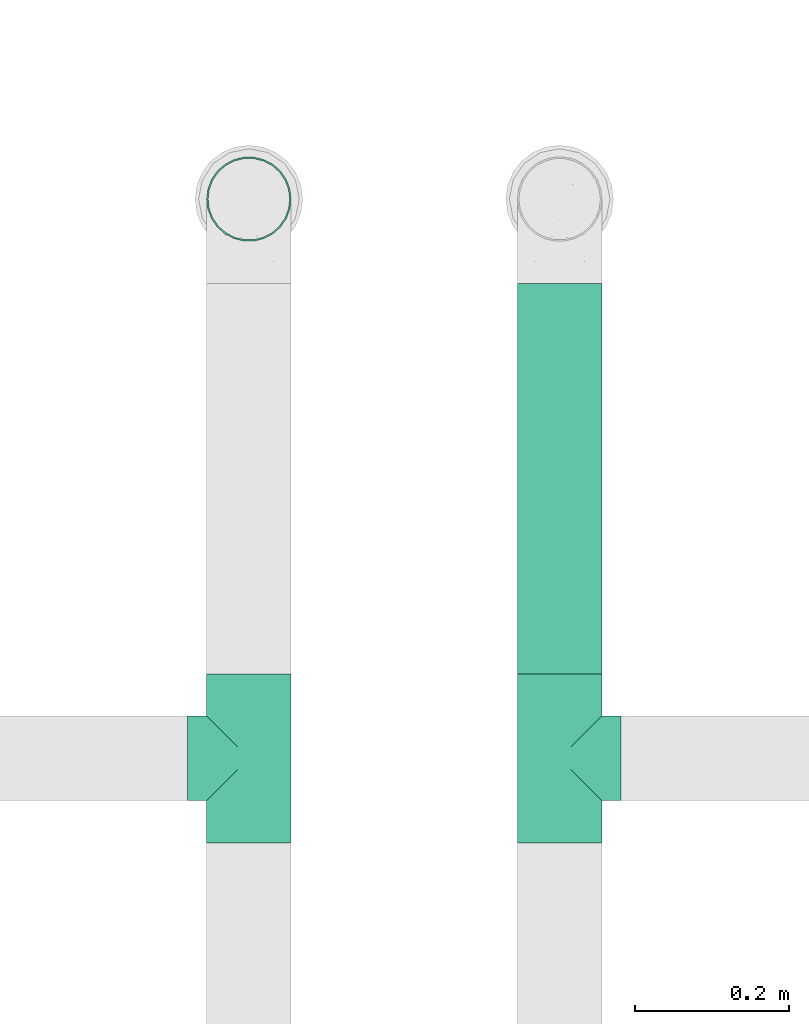
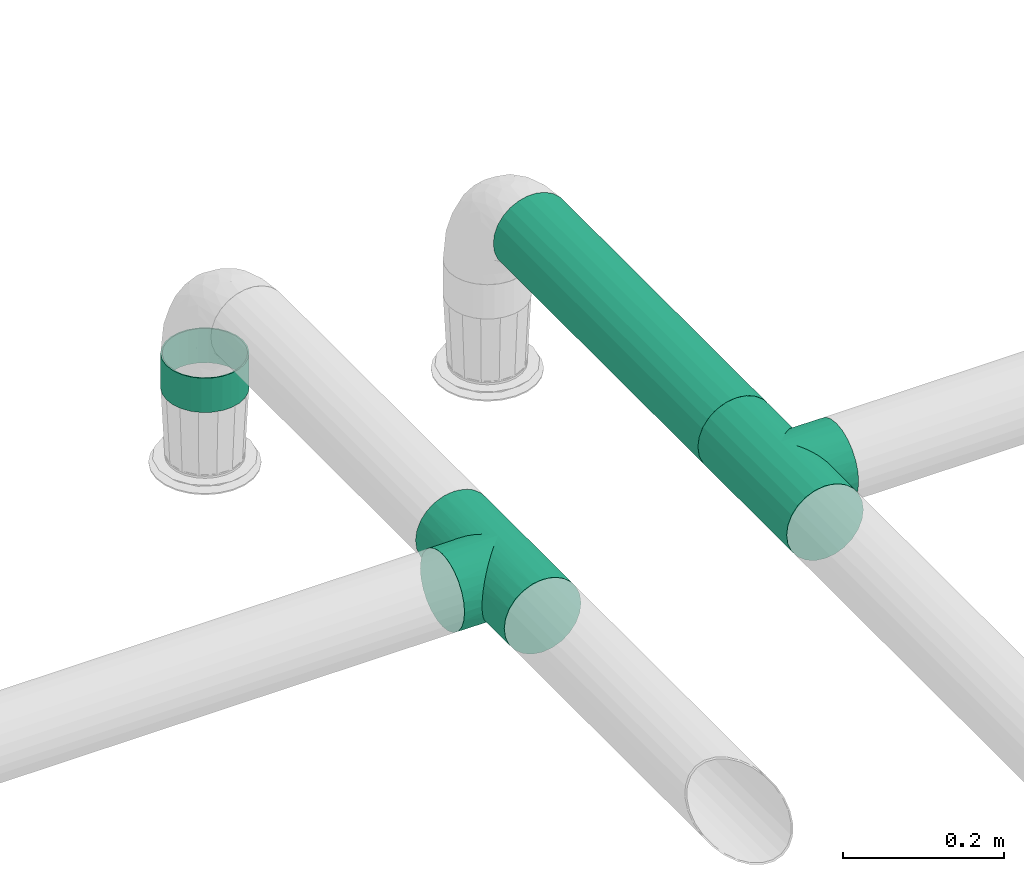
# One storey, part 31 of 115: 2 flow fittings, 2 flow segments.
"""IFC2X3 building model written with IfcOpenShell, lengths in millimetres."""

from ifc_helpers import new_model, entity, si_unit, converted_unit, derived_unit, direction, frame, origin_with_axes, origin_2d_with_axis, place, context, subcontext, project, spatial, hollow_circle, extrude, open_shell, surface_model, source, transform, mapped, material, layer, layer_set, layer_usage, type_object, element, save


model = new_model("IFC2X3")

# Units and contexts
model_context = context("Model", 3, precision=1e-05, world=origin_with_axes(), true_north=direction((0.0, 1.0)))
body_context = subcontext(model_context, "Body", "Model", "MODEL_VIEW")
ifc_project = project(units=[si_unit("AREAUNIT", "SQUARE_METRE"), si_unit("VOLUMEUNIT", "CUBIC_METRE", prefix="DECI"), si_unit("TIMEUNIT", "SECOND"), si_unit("THERMODYNAMICTEMPERATUREUNIT", "DEGREE_CELSIUS"), si_unit("PRESSUREUNIT", "PASCAL"), si_unit("MASSUNIT", "GRAM", prefix="KILO"), si_unit("LENGTHUNIT", "METRE", prefix="MILLI"), si_unit("POWERUNIT", "WATT"), si_unit("ELECTRICCURRENTUNIT", "AMPERE"), si_unit("ELECTRICVOLTAGEUNIT", "VOLT"), derived_unit("VOLUMETRICFLOWRATEUNIT", [(si_unit("VOLUMEUNIT", "CUBIC_METRE", prefix="DECI"), 1), (si_unit("TIMEUNIT", "SECOND"), -1)]), derived_unit("LINEARVELOCITYUNIT", [(si_unit("LENGTHUNIT", "METRE"), 1), (si_unit("TIMEUNIT", "SECOND"), -1)]), derived_unit("MASSDENSITYUNIT", [(si_unit("MASSUNIT", "GRAM", prefix="KILO"), 1), (si_unit("VOLUMEUNIT", "CUBIC_METRE"), -1)]), converted_unit("PLANEANGLEUNIT", "DEGREE", entity("IfcRatioMeasure", 0.01745), si_unit("PLANEANGLEUNIT", "RADIAN"), dimensions=[0, 0, 0, 0, 0, 0, 0])], contexts=[model_context])

# Site, building, storey
site_placement = place(None, origin_with_axes())
site = spatial("IfcSite", under=ifc_project, at=site_placement, CompositionType="ELEMENT")
building_placement = place(site_placement, origin_with_axes())
building = spatial("IfcBuilding", under=site, at=building_placement, Name="mc-building", CompositionType="ELEMENT")
storey_placement = place(building_placement, frame((0.0, 0.0, 2950.0), z_axis=(0.0, 0.0, 1.0), x_axis=(1.0, 0.0, 0.0)))
storey = spatial("IfcBuildingStorey", under=building, at=storey_placement, Name="2. Korrus", CompositionType="ELEMENT", Elevation=2950.0)

# Flow fitting
duct_fitting_type = type_object("IfcDuctFittingType", PredefinedType="JUNCTION")
shared_shape_1 = source(origin_with_axes(), body_context, "Body", "SurfaceModel", [
    surface_model("IfcShellBasedSurfaceModel", [(0.0, -80.0, -55.0), (14.23505, -80.0, -53.12592), (-14.23505, -80.0, -53.12592), (-53.12592, -80.0, 14.23505), (-27.5, -80.0, -47.63139), (-47.63139, -80.0, -27.5), (-38.89087, -80.0, -38.89087), (55.0, -80.0, 0.0), (53.12592, -80.0, 14.23505), (38.89087, -80.0, -38.89087), (27.5, -80.0, -47.63139), (53.12592, -80.0, -14.23505), (47.63139, -80.0, -27.5), (-53.12592, -80.0, -14.23505), (-47.63139, -80.0, 27.5), (-38.89087, -80.0, 38.89087), (14.23505, -80.0, 53.12592), (-27.5, -80.0, 47.63139), (-14.23505, -80.0, 53.12592), (47.63139, -80.0, 27.5), (38.89087, -80.0, 38.89087), (27.5, -80.0, 47.63139), (0.0, -80.0, 55.0), (-55.0, -80.0, 0.0), (0.0, 0.0, 55.0), (-7.4066, -7.4066, 54.49901), (-14.74521, -14.74521, 52.98659), (-21.93978, -21.93978, 50.43457), (-28.89905, -28.89905, 46.79578), (-35.50357, -35.50357, 42.00591), (-41.58668, -41.58668, 35.99373), (-46.92319, -46.92319, 28.69171), (-51.19777, -51.19777, 20.0945), (-50.37866, -80.0, 20.86752), (-54.01174, -54.01174, 10.37938), (-55.0, -55.0, 0.0), (-54.06296, -80.0, 7.11752), (-54.01174, -54.01174, -10.37938), (-51.19777, -51.19777, -20.0945), (-54.06296, -80.0, -7.11752), (-46.92319, -46.92319, -28.69171), (-41.58668, -41.58668, -35.99373), (-50.37866, -80.0, -20.86752), (-35.50357, -35.50357, -42.00591), (-21.93978, -21.93978, -50.43457), (-14.74521, -14.74521, -52.98659), (-7.4066, -7.4066, -54.49901), (0.0, 0.0, -55.0), (-28.89905, -28.89905, -46.79578), (7.4066, -7.4066, -54.49901), (14.74521, -14.74521, -52.98659), (21.93978, -21.93978, -50.43457), (28.89905, -28.89905, -46.79578), (35.50357, -35.50357, -42.00591), (41.58668, -41.58668, -35.99373), (46.92319, -46.92319, -28.69171), (51.19777, -51.19777, -20.0945), (50.37866, -80.0, -20.86752), (54.01174, -54.01174, -10.37938), (55.0, -55.0, 0.0), (54.06296, -80.0, -7.11752), (54.01174, -54.01174, 10.37938), (51.19777, -51.19777, 20.0945), (54.06296, -80.0, 7.11752), (46.92319, -46.92319, 28.69171), (41.58668, -41.58668, 35.99373), (50.37866, -80.0, 20.86752), (35.50357, -35.50357, 42.00591), (21.93978, -21.93978, 50.43457), (14.74521, -14.74521, 52.98659), (7.4066, -7.4066, 54.49901), (28.89905, -28.89905, 46.79578), (-110.0, 0.0, -55.0), (-110.0, -14.23505, -53.12592), (-110.0, 14.23505, -53.12592), (-110.0, 53.12592, 14.23505), (-110.0, 27.5, -47.63139), (-110.0, 47.63139, -27.5), (-110.0, 38.89087, -38.89087), (-110.0, -55.0, 0.0), (-110.0, -53.12592, 14.23505), (-110.0, -38.89087, -38.89087), (-110.0, -27.5, -47.63139), (-110.0, -53.12592, -14.23505), (-110.0, -47.63139, -27.5), (-110.0, 53.12592, -14.23505), (-110.0, 47.63139, 27.5), (-110.0, 38.89087, 38.89087), (-110.0, -14.23505, 53.12592), (-110.0, 27.5, 47.63139), (-110.0, 14.23505, 53.12592), (-110.0, -47.63139, 27.5), (-110.0, -38.89087, 38.89087), (-110.0, -27.5, 47.63139), (-110.0, 0.0, 55.0), (-110.0, 55.0, 0.0), (110.0, 55.0, 0.0), (110.0, 0.0, -55.0), (110.0, 14.23505, -53.12592), (110.0, 27.5, -47.63139), (110.0, 38.89087, -38.89087), (110.0, 47.63139, -27.5), (110.0, -38.89087, -38.89087), (110.0, -53.12592, 14.23505), (110.0, -27.5, -47.63139), (110.0, -14.23505, -53.12592), (110.0, -47.63139, -27.5), (110.0, -53.12592, -14.23505), (110.0, -55.0, 0.0), (110.0, 53.12592, -14.23505), (110.0, 53.12592, 14.23505), (110.0, 47.63139, 27.5), (110.0, 38.89087, 38.89087), (110.0, 0.0, 55.0), (110.0, 27.5, 47.63139), (110.0, 14.23505, 53.12592), (110.0, -47.63139, 27.5), (110.0, -38.89087, 38.89087), (110.0, -27.5, 47.63139), (110.0, -14.23505, 53.12592)], [open_shell([[[0, 1, 2]], [[2, 3, 4]], [[5, 6, 3]], [[6, 4, 3]], [[2, 7, 8]], [[9, 7, 10]], [[1, 10, 7]], [[11, 7, 12]], [[9, 12, 7]], [[7, 2, 1]], [[5, 3, 13]], [[2, 14, 3]], [[2, 15, 14]], [[2, 16, 17]], [[17, 15, 2]], [[16, 18, 17]], [[2, 8, 19]], [[2, 19, 20]], [[2, 20, 21]], [[16, 2, 21]], [[16, 22, 18]], [[23, 13, 3]], [[24, 25, 22]], [[26, 27, 18]], [[25, 26, 18]], [[22, 25, 18]], [[17, 28, 29]], [[17, 18, 27]], [[17, 29, 15]], [[28, 17, 27]], [[30, 31, 14]], [[32, 3, 33]], [[32, 34, 3]], [[35, 36, 34]], [[31, 32, 14]], [[15, 30, 14]], [[34, 36, 3]], [[33, 14, 32]], [[36, 35, 23]], [[30, 15, 29]], [[37, 38, 13]], [[37, 13, 39]], [[40, 41, 5]], [[38, 5, 42]], [[38, 40, 5]], [[37, 39, 35]], [[35, 39, 23]], [[13, 38, 42]], [[41, 6, 5]], [[41, 43, 6]], [[44, 45, 2]], [[46, 47, 0]], [[45, 46, 2]], [[43, 48, 4]], [[44, 4, 48]], [[44, 2, 4]], [[46, 0, 2]], [[43, 4, 6]], [[47, 49, 0]], [[50, 51, 1]], [[49, 50, 1]], [[0, 49, 1]], [[10, 52, 53]], [[10, 1, 51]], [[10, 53, 9]], [[52, 10, 51]], [[54, 55, 12]], [[56, 11, 57]], [[56, 58, 11]], [[59, 60, 58]], [[55, 56, 12]], [[9, 54, 12]], [[58, 60, 11]], [[57, 12, 56]], [[60, 59, 7]], [[54, 9, 53]], [[61, 62, 8]], [[61, 8, 63]], [[64, 65, 19]], [[62, 19, 66]], [[62, 64, 19]], [[61, 63, 59]], [[7, 59, 63]], [[62, 66, 8]], [[65, 20, 19]], [[65, 67, 20]], [[68, 69, 16]], [[70, 24, 22]], [[69, 70, 16]], [[67, 71, 21]], [[68, 21, 71]], [[68, 16, 21]], [[70, 22, 16]], [[67, 21, 20]], [[72, 73, 74]], [[74, 75, 76]], [[77, 78, 75]], [[76, 75, 78]], [[74, 79, 80]], [[81, 79, 82]], [[73, 82, 79]], [[83, 79, 84]], [[81, 84, 79]], [[79, 74, 73]], [[77, 75, 85]], [[74, 86, 75]], [[74, 87, 86]], [[74, 88, 89]], [[89, 87, 74]], [[88, 90, 89]], [[74, 91, 92]], [[91, 74, 80]], [[92, 93, 74]], [[74, 93, 88]], [[88, 94, 90]], [[95, 85, 75]], [[96, 97, 98]], [[99, 96, 98]], [[96, 100, 101]], [[100, 96, 99]], [[102, 97, 103]], [[97, 102, 104]], [[104, 105, 97]], [[102, 103, 106]], [[106, 103, 107]], [[108, 107, 103]], [[109, 96, 101]], [[110, 111, 97]], [[97, 111, 112]], [[113, 97, 114]], [[97, 112, 114]], [[113, 114, 115]], [[116, 103, 97]], [[117, 116, 97]], [[118, 117, 97]], [[119, 118, 97]], [[119, 97, 113]], [[96, 110, 97]], [[24, 113, 115]], [[89, 115, 114]], [[94, 24, 90]], [[90, 24, 115]], [[115, 89, 90]], [[114, 87, 89]], [[86, 112, 111]], [[75, 111, 110]], [[95, 110, 96]], [[87, 112, 86]], [[86, 111, 75]], [[110, 95, 75]], [[112, 87, 114]], [[85, 96, 109]], [[77, 109, 101]], [[95, 96, 85]], [[85, 109, 77]], [[101, 78, 77]], [[101, 100, 78]], [[76, 100, 99]], [[74, 99, 98]], [[47, 98, 97]], [[76, 99, 74]], [[47, 72, 74]], [[98, 47, 74]], [[100, 76, 78]], [[47, 46, 72]], [[45, 44, 73]], [[46, 45, 73]], [[72, 46, 73]], [[82, 48, 43]], [[82, 73, 44]], [[82, 43, 81]], [[48, 82, 44]], [[41, 40, 84]], [[38, 37, 83]], [[40, 38, 84]], [[81, 41, 84]], [[37, 79, 83]], [[83, 84, 38]], [[79, 37, 35]], [[41, 81, 43]], [[49, 97, 105]], [[105, 104, 51]], [[53, 104, 102]], [[53, 52, 104]], [[49, 47, 97]], [[51, 50, 105]], [[52, 51, 104]], [[49, 105, 50]], [[54, 102, 106]], [[56, 106, 107]], [[58, 107, 108]], [[55, 54, 106]], [[58, 56, 107]], [[59, 58, 108]], [[55, 106, 56]], [[102, 54, 53]], [[34, 32, 80]], [[31, 30, 91]], [[32, 31, 91]], [[35, 34, 79]], [[80, 79, 34]], [[32, 91, 80]], [[30, 92, 91]], [[30, 29, 92]], [[27, 26, 88]], [[25, 24, 94]], [[26, 25, 88]], [[29, 28, 93]], [[27, 93, 28]], [[27, 88, 93]], [[25, 94, 88]], [[29, 93, 92]], [[61, 108, 103]], [[62, 103, 116]], [[65, 116, 117]], [[61, 59, 108]], [[64, 62, 116]], [[65, 64, 116]], [[61, 103, 62]], [[117, 67, 65]], [[71, 67, 118]], [[118, 67, 117]], [[68, 118, 119]], [[70, 119, 113]], [[68, 71, 118]], [[70, 69, 119]], [[24, 70, 113]], [[68, 119, 69]]])]),
])
flow_fitting_1_placement = place(storey_placement, frame((16200.78197, 3666.26111, 2465.0), z_axis=(0.0, 0.0, 1.0), x_axis=(0.0, 1.0, 0.0)))
element("IfcFlowFitting", 1, at=flow_fitting_1_placement, inside=storey, type_object=duct_fitting_type, context=body_context, shape_type="MappedRepresentation", body=[
    mapped(shared_shape_1, transform((0.0, 0.0, 0.0), scale=1.0)),
])

# Flow segment
ifc_material = material(Name="FZ1")
ifc_layer = layer(ifc_material, 0.0)
ifc_layer_set = layer_set([ifc_layer], Name="FZ1")
ifc_layer_usage = layer_usage(ifc_layer_set, "AXIS1", "POSITIVE", 0.0)
duct_segment_type = type_object("IfcDuctSegmentType", PredefinedType="RIGIDSEGMENT")
shared_shape_2 = source(origin_with_axes(), body_context, "Body", "SweptSolid", [
    extrude(hollow_circle(Radius=55.0, WallThickness=2.0, at=origin_2d_with_axis()), frame((0.0, 0.0, 0.0), z_axis=(1.0, 0.0, 0.0), x_axis=(0.0, 1.0, 0.0)), (0.0, 0.0, 1.0), 51.9),
])
flow_segment_1_placement = place(storey_placement, frame((15796.4103, 4393.85998, 2355.0), z_axis=(0.0, -1.0, 0.0), x_axis=(0.0, 0.0, -1.0)))
element("IfcFlowSegment", 2, at=flow_segment_1_placement, inside=storey, type_object=duct_segment_type, material=ifc_layer_usage, context=body_context, shape_type="MappedRepresentation", body=[
    mapped(shared_shape_2, transform((0.0, 0.0, 0.0), scale=1.0)),
])

# Flow fitting
shared_shape_3 = source(origin_with_axes(), body_context, "Body", "SurfaceModel", [
    surface_model("IfcShellBasedSurfaceModel", [(-110.0, -38.89087, -38.89087), (-110.0, -55.0, 0.0), (-110.0, -27.5, -47.63139), (-110.0, -53.12592, -14.23505), (-110.0, -47.63139, -27.5), (-110.0, 47.63139, -27.5), (-110.0, 53.12592, 14.23505), (-110.0, 53.12592, -14.23505), (-110.0, 55.0, 0.0), (110.0, 38.89087, -38.89087), (110.0, 55.0, 0.0), (110.0, 27.5, -47.63139), (110.0, -38.89087, -38.89087), (110.0, -53.12592, 14.23505), (110.0, -47.63139, -27.5), (110.0, -55.0, 0.0), (110.0, -53.12592, -14.23505), (110.0, 53.12592, -14.23505), (110.0, 47.63139, -27.5), (-110.0, 38.89087, -38.89087), (-110.0, -14.23505, -53.12592), (-110.0, 0.0, -55.0), (-110.0, 27.5, -47.63139), (-110.0, 14.23505, -53.12592), (-110.0, -53.12592, 14.23505), (-110.0, -47.63139, 27.5), (-110.0, -38.89087, 38.89087), (-110.0, 14.23505, 53.12592), (-110.0, 27.5, 47.63139), (-55.0, 80.0, 0.0), (0.0, 80.0, -55.0), (-14.23505, 80.0, -53.12592), (-27.5, 80.0, -47.63139), (-38.89087, 80.0, -38.89087), (-47.63139, 80.0, -27.5), (38.89087, 80.0, -38.89087), (53.12592, 80.0, 14.23505), (27.5, 80.0, -47.63139), (14.23505, 80.0, -53.12592), (47.63139, 80.0, -27.5), (53.12592, 80.0, -14.23505), (55.0, 80.0, 0.0), (-53.12592, 80.0, -14.23505), (-53.12592, 80.0, 14.23505), (-47.63139, 80.0, 27.5), (-38.89087, 80.0, 38.89087), (0.0, 80.0, 55.0), (-27.5, 80.0, 47.63139), (-14.23505, 80.0, 53.12592), (47.63139, 80.0, 27.5), (38.89087, 80.0, 38.89087), (27.5, 80.0, 47.63139), (14.23505, 80.0, 53.12592), (-7.4066, 7.4066, 54.49901), (0.0, 0.0, 55.0), (-21.93978, 21.93978, 50.43457), (-14.74521, 14.74521, 52.98659), (-35.50357, 35.50357, 42.00591), (-28.89905, 28.89905, 46.79578), (-46.92319, 46.92319, 28.69171), (-41.58668, 41.58668, 35.99373), (-54.01174, 54.01174, 10.37938), (-54.06296, 80.0, 7.11752), (-55.0, 55.0, 0.0), (-51.19777, 51.19777, 20.0945), (-50.37866, 80.0, 20.86752), (-51.19777, 51.19777, -20.0945), (-54.01174, 54.01174, -10.37938), (-50.37866, 80.0, -20.86752), (-41.58668, 41.58668, -35.99373), (-46.92319, 46.92319, -28.69171), (-54.06296, 80.0, -7.11752), (-35.50357, 35.50357, -42.00591), (-14.74521, 14.74521, -52.98659), (-21.93978, 21.93978, -50.43457), (0.0, 0.0, -55.0), (-7.4066, 7.4066, -54.49901), (-28.89905, 28.89905, -46.79578), (7.4066, 7.4066, -54.49901), (21.93978, 21.93978, -50.43457), (14.74521, 14.74521, -52.98659), (35.50357, 35.50357, -42.00591), (28.89905, 28.89905, -46.79578), (46.92319, 46.92319, -28.69171), (41.58668, 41.58668, -35.99373), (54.01174, 54.01174, -10.37938), (54.06296, 80.0, -7.11752), (55.0, 55.0, 0.0), (51.19777, 51.19777, -20.0945), (50.37866, 80.0, -20.86752), (51.19777, 51.19777, 20.0945), (54.01174, 54.01174, 10.37938), (50.37866, 80.0, 20.86752), (41.58668, 41.58668, 35.99373), (46.92319, 46.92319, 28.69171), (54.06296, 80.0, 7.11752), (35.50357, 35.50357, 42.00591), (14.74521, 14.74521, 52.98659), (21.93978, 21.93978, 50.43457), (7.4066, 7.4066, 54.49901), (28.89905, 28.89905, 46.79578), (-110.0, -27.5, 47.63139), (-110.0, 0.0, 55.0), (-110.0, -14.23505, 53.12592), (-110.0, 47.63139, 27.5), (-110.0, 38.89087, 38.89087), (110.0, 0.0, -55.0), (110.0, 14.23505, -53.12592), (110.0, -14.23505, -53.12592), (110.0, -27.5, -47.63139), (110.0, 53.12592, 14.23505), (110.0, -47.63139, 27.5), (110.0, -38.89087, 38.89087), (110.0, 14.23505, 53.12592), (110.0, -27.5, 47.63139), (110.0, -14.23505, 53.12592), (110.0, 47.63139, 27.5), (110.0, 38.89087, 38.89087), (110.0, 27.5, 47.63139), (110.0, 0.0, 55.0)], [open_shell([[[0, 1, 2]], [[3, 1, 4]], [[5, 6, 7]], [[8, 7, 6]], [[9, 10, 11]], [[12, 13, 14]], [[15, 16, 13]], [[17, 10, 18]], [[19, 6, 5]], [[2, 1, 20]], [[19, 21, 6]], [[21, 19, 22]], [[22, 23, 21]], [[24, 25, 21]], [[21, 25, 26]], [[27, 28, 21]], [[29, 30, 31]], [[32, 29, 31]], [[29, 33, 34]], [[29, 32, 33]], [[35, 30, 36]], [[30, 35, 37]], [[37, 38, 30]], [[35, 36, 39]], [[39, 36, 40]], [[41, 40, 36]], [[42, 29, 34]], [[43, 44, 30]], [[30, 44, 45]], [[46, 30, 47]], [[30, 45, 47]], [[46, 47, 48]], [[49, 36, 30]], [[50, 49, 30]], [[51, 50, 30]], [[52, 51, 30]], [[52, 30, 46]], [[29, 43, 30]], [[46, 53, 54]], [[48, 55, 56]], [[48, 56, 53]], [[48, 53, 46]], [[57, 58, 47]], [[55, 48, 47]], [[45, 57, 47]], [[55, 47, 58]], [[44, 59, 60]], [[61, 62, 63]], [[43, 61, 64]], [[65, 43, 64]], [[44, 64, 59]], [[44, 60, 45]], [[43, 62, 61]], [[64, 44, 65]], [[29, 63, 62]], [[57, 45, 60]], [[42, 66, 67]], [[68, 34, 66]], [[34, 69, 70]], [[71, 42, 67]], [[34, 70, 66]], [[63, 71, 67]], [[29, 71, 63]], [[68, 66, 42]], [[34, 33, 69]], [[33, 72, 69]], [[31, 73, 74]], [[30, 75, 76]], [[31, 76, 73]], [[32, 77, 72]], [[77, 32, 74]], [[32, 31, 74]], [[31, 30, 76]], [[33, 32, 72]], [[30, 78, 75]], [[38, 79, 80]], [[38, 80, 78]], [[38, 78, 30]], [[81, 82, 37]], [[79, 38, 37]], [[35, 81, 37]], [[79, 37, 82]], [[39, 83, 84]], [[85, 86, 87]], [[40, 85, 88]], [[89, 40, 88]], [[39, 88, 83]], [[39, 84, 35]], [[40, 86, 85]], [[88, 39, 89]], [[41, 87, 86]], [[81, 35, 84]], [[36, 90, 91]], [[92, 49, 90]], [[49, 93, 94]], [[95, 36, 91]], [[49, 94, 90]], [[87, 95, 91]], [[95, 87, 41]], [[36, 92, 90]], [[49, 50, 93]], [[50, 96, 93]], [[52, 97, 98]], [[46, 54, 99]], [[52, 99, 97]], [[51, 100, 96]], [[100, 51, 98]], [[51, 52, 98]], [[52, 46, 99]], [[50, 51, 96]], [[1, 21, 20]], [[1, 0, 4]], [[101, 102, 26]], [[102, 21, 26]], [[102, 101, 103]], [[104, 6, 21]], [[105, 104, 21]], [[105, 21, 28]], [[21, 102, 27]], [[1, 24, 21]], [[106, 107, 108]], [[108, 13, 109]], [[109, 13, 12]], [[108, 10, 110]], [[107, 11, 10]], [[9, 18, 10]], [[10, 108, 107]], [[16, 14, 13]], [[108, 111, 13]], [[108, 112, 111]], [[108, 113, 114]], [[114, 112, 108]], [[113, 115, 114]], [[108, 110, 116]], [[108, 116, 117]], [[108, 117, 118]], [[113, 108, 118]], [[113, 119, 115]], [[115, 119, 54]], [[114, 115, 101]], [[103, 54, 102]], [[115, 54, 103]], [[103, 101, 115]], [[101, 26, 114]], [[111, 112, 25]], [[13, 111, 24]], [[15, 13, 1]], [[25, 112, 26]], [[24, 111, 25]], [[24, 1, 13]], [[114, 26, 112]], [[16, 15, 3]], [[14, 16, 4]], [[3, 15, 1]], [[4, 16, 3]], [[4, 0, 14]], [[0, 12, 14]], [[109, 12, 2]], [[108, 109, 20]], [[106, 108, 75]], [[20, 109, 2]], [[20, 21, 75]], [[20, 75, 108]], [[0, 2, 12]], [[21, 76, 75]], [[23, 74, 73]], [[23, 73, 76]], [[23, 76, 21]], [[72, 77, 22]], [[74, 23, 22]], [[19, 72, 22]], [[74, 22, 77]], [[5, 70, 69]], [[7, 67, 66]], [[5, 66, 70]], [[5, 69, 19]], [[7, 8, 67]], [[66, 5, 7]], [[63, 67, 8]], [[72, 19, 69]], [[107, 106, 78]], [[79, 11, 107]], [[9, 11, 81]], [[11, 82, 81]], [[106, 75, 78]], [[107, 80, 79]], [[11, 79, 82]], [[80, 107, 78]], [[18, 9, 84]], [[17, 18, 88]], [[10, 17, 85]], [[18, 84, 83]], [[17, 88, 85]], [[10, 85, 87]], [[88, 18, 83]], [[81, 84, 9]], [[110, 10, 91]], [[116, 110, 90]], [[117, 116, 93]], [[10, 87, 91]], [[116, 90, 94]], [[116, 94, 93]], [[90, 110, 91]], [[93, 96, 117]], [[118, 96, 100]], [[117, 96, 118]], [[113, 118, 98]], [[119, 113, 99]], [[118, 100, 98]], [[113, 97, 99]], [[119, 99, 54]], [[97, 113, 98]], [[6, 64, 61]], [[104, 60, 59]], [[104, 59, 64]], [[8, 61, 63]], [[61, 8, 6]], [[6, 104, 64]], [[104, 105, 60]], [[105, 57, 60]], [[27, 56, 55]], [[102, 54, 53]], [[27, 53, 56]], [[28, 58, 57]], [[58, 28, 55]], [[28, 27, 55]], [[27, 102, 53]], [[105, 28, 57]]])]),
])
flow_fitting_2_placement = place(storey_placement, frame((15796.4103, 3666.26111, 2465.0), z_axis=(0.0, 0.0, 1.0), x_axis=(0.0, 1.0, 0.0)))
element("IfcFlowFitting", 3, at=flow_fitting_2_placement, inside=storey, type_object=duct_fitting_type, context=body_context, shape_type="MappedRepresentation", body=[
    mapped(shared_shape_3, transform((0.0, 0.0, 0.0), scale=1.0)),
])

# Flow segment
shared_shape_4 = source(origin_with_axes(), body_context, "Body", "SweptSolid", [
    extrude(hollow_circle(Radius=55.0, WallThickness=2.0, at=origin_2d_with_axis()), frame((0.0, 0.0, 0.0), z_axis=(1.0, 0.0, 0.0), x_axis=(0.0, 1.0, 0.0)), (0.0, 0.0, 1.0), 507.6),
])
flow_segment_2_placement = place(storey_placement, frame((16200.78197, 3776.26111, 2465.0), z_axis=(0.0, 0.0, 1.0), x_axis=(0.0, 1.0, 0.0)))
element("IfcFlowSegment", 4, at=flow_segment_2_placement, inside=storey, type_object=duct_segment_type, material=ifc_layer_usage, context=body_context, shape_type="MappedRepresentation", body=[
    mapped(shared_shape_4, transform((0.0, 0.0, 0.0), scale=1.0)),
])

save(model, "model.ifc")
